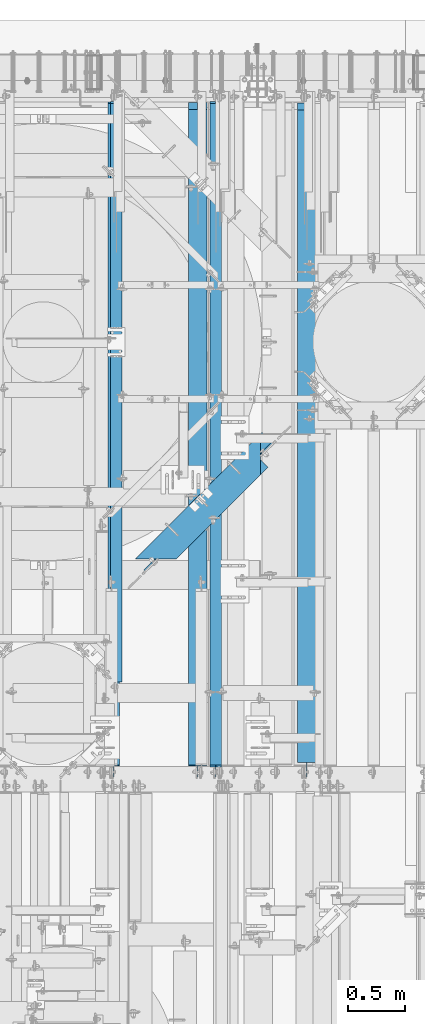
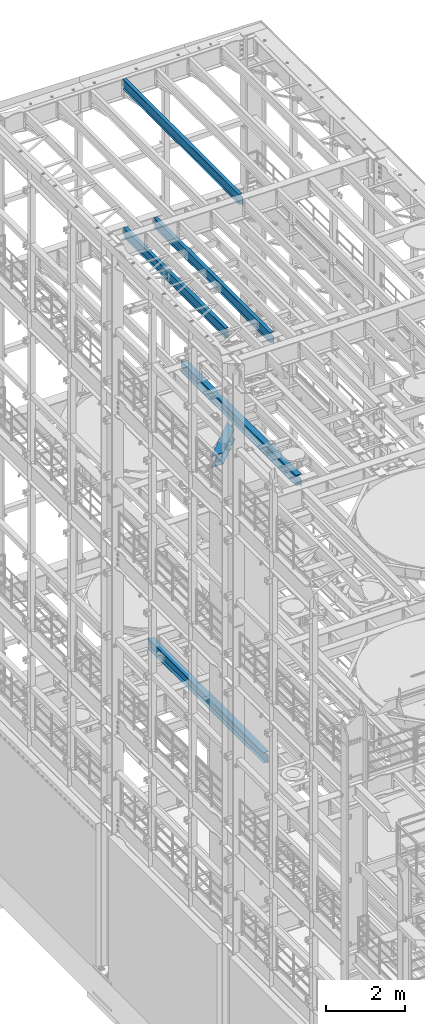
# One storey, part 1060 of 1876: 6 beams, 6 elements without a shape of their own.
"""IFC2X3 building model written with IfcOpenShell, lengths in millimetres."""

from ifc_helpers import new_model, si_unit, frame, origin_with_axes, place, context, subcontext, project, spatial, faceted_brep, material, type_object, element, aggregate, save


model = new_model("IFC2X3")

# Units and contexts
model_context = context("Model", 3, precision=1e-05, world=origin_with_axes())
body_context = subcontext(model_context, "Body", "Model", "MODEL_VIEW")
ifc_project = project(units=[si_unit("LENGTHUNIT", "METRE", prefix="MILLI"), si_unit("AREAUNIT", "SQUARE_METRE"), si_unit("VOLUMEUNIT", "CUBIC_METRE"), si_unit("MASSUNIT", "GRAM", prefix="KILO"), si_unit("TIMEUNIT", "SECOND"), si_unit("PLANEANGLEUNIT", "RADIAN"), si_unit("SOLIDANGLEUNIT", "STERADIAN"), si_unit("THERMODYNAMICTEMPERATUREUNIT", "DEGREE_CELSIUS"), si_unit("LUMINOUSINTENSITYUNIT", "LUMEN")], contexts=[model_context])

# Site, building, storey
site_placement = place(None, origin_with_axes())
site = spatial("IfcSite", under=ifc_project, at=site_placement, CompositionType="ELEMENT")
building_placement = place(site_placement, origin_with_axes())
building = spatial("IfcBuilding", under=site, at=building_placement, Name="Undefined", CompositionType="ELEMENT")
storey_placement = place(building_placement, origin_with_axes())
storey = spatial("IfcBuildingStorey", under=building, at=storey_placement, Name="Undefined", CompositionType="ELEMENT", Elevation=0.0)

# Assembly, beam
assembly_1_placement = place(storey_placement, origin_with_axes())
assembly_1 = element("IfcElementAssembly", 1, at=assembly_1_placement, inside=storey, Name="BEAM", AssemblyPlace="NOTDEFINED", PredefinedType="RIGID_FRAME")
ifc_material = material(Name="STEEL/A992")
beam_type_1 = type_object("IfcBeamType", Name="W12X16", PredefinedType="NOTDEFINED")
beam_1_placement = place(assembly_1_placement, frame((4711.7, 7620.0, 17830.8), z_axis=(0.0, 0.0, 1.0), x_axis=(0.0, 1.0, 0.0)))
beam_1 = element("IfcBeam", 2, at=beam_1_placement, type_object=beam_type_1, material=ifc_material, Name="BEAM", ObjectType="W12X16", context=body_context, shape_type="Brep", body=[
    faceted_brep([(19.84375, -3.17499999999995, -126.999999999996), (19.84375, 3.17499999999995, -126.999999999996), (96.0437501907345, 3.17500002364682, -126.999999999996), (96.0437501907345, -3.17499999999995, -126.999999999996), (100.90382970878, 3.17500002380461, -127.966729922584), (100.90382970878, -3.17499999999995, -127.966729922584), (105.024006176934, 3.17500002425209, -130.719743823061), (105.024006176934, -3.17499999999995, -130.719743823061), (107.777020077412, 3.17500002492102, -134.839920291215), (107.777020077412, -3.17499999999995, -134.839920291215), (108.74375, -3.17499999999995, -139.699999809261), (108.74375, 3.17500002570978, -139.699999809261), (108.74375, 3.17500009516311, -146.049999999999), (108.74375, 50.8, -146.049999999999), (108.74375, 50.8, -152.400000000001), (108.74375, -50.8, -152.400000000001), (108.74375, -50.8, -146.049999999999), (108.74375, -3.17499999999995, -146.049999999999), (5969.79375, 50.8, 146.049999999999), (5969.79375, 3.17499999999995, 146.049999999999), (126.20625, 3.17499999999995, 146.049999999999), (126.20625, 50.8, 146.049999999999), (113.506250190735, -3.17499999999995, 107.950000000004), (113.506250190735, 3.17499998606149, 107.950000000004), (19.84375, 3.17499999999995, 107.950000000004), (19.84375, -3.17499999999995, 107.950000000004), (118.366329708781, -3.17499999999995, 108.916729922592), (118.366329708781, 3.17499998590552, 108.916729922592), (122.486506176934, -3.17499999999995, 111.669743823069), (122.486506176934, 3.17499998546009, 111.669743823069), (125.239520077413, -3.17499999999995, 115.789920291223), (125.239520077413, 3.17499998479298, 115.789920291223), (126.20625, -3.17499999999995, 120.64999980927), (126.20625, 3.17499998400558, 120.64999980927), (5969.79375, -50.8, 152.400000000001), (5969.79375, 50.8, 152.400000000001), (126.20625, 50.8, 152.400000000001), (126.20625, -50.8, 152.400000000001), (5969.79375, -50.8, 146.049999999999), (126.20625, -50.8, 146.049999999999), (5969.79375, -3.17499999999995, 146.049999999999), (126.20625, -3.17499999999995, 146.049999999999), (5969.79375, -3.17499999999995, 120.64999980927), (5969.79375, 3.17499999999995, 120.64999980927), (5970.76047992259, -3.17499999999995, 115.789920291223), (5970.76047992259, 3.17499999999995, 115.789920291223), (5973.51349382307, -3.17499999999995, 111.669743823069), (5973.51349382307, 3.17499999999995, 111.669743823069), (5977.63367029122, -3.17499999999995, 108.916729922592), (5977.63367029122, 3.17499999999995, 108.916729922592), (5982.49374980927, -3.17499999999995, 107.950000000004), (5982.49374980927, 3.17499999999995, 107.950000000004), (6076.15625, -3.17499999999995, 107.950000000004), (6076.15625, 3.17499999999995, 107.950000000004), (6076.15625, -3.17499999999995, -126.999999999996), (6076.15625, 3.17499999999995, -126.999999999996), (5999.95624980926, -3.17499999999995, -126.999999999996), (5999.95624980926, 3.17499999999995, -126.999999999996), (5995.09617029122, -3.17499999999995, -127.966729922584), (5995.09617029122, 3.17499999999995, -127.966729922584), (5990.97599382306, -3.17499999999995, -130.719743823061), (5990.97599382306, 3.17499999999995, -130.719743823061), (5988.22297992259, -3.17499999999995, -134.839920291215), (5988.22297992259, 3.17499999999995, -134.839920291215), (5987.25625, -3.17499999999995, -139.699999809261), (5987.25625, 3.17499999999995, -139.699999809261), (5987.25625, -3.17499999999995, -146.049999999999), (5987.25625, -50.8, -146.049999999999), (5987.25625, -50.8, -152.400000000001), (5987.25625, 50.8, -152.400000000001), (5987.25625, 50.8, -146.049999999999), (5987.25625, 3.17499999999995, -146.049999999999)], [[[0, 1, 2, 3]], [[3, 2, 4, 5]], [[5, 4, 6, 7]], [[7, 6, 8, 9]], [[10, 11, 12, 13, 14, 15, 16, 17]], [[9, 8, 11, 10]], [[18, 19, 20, 21]], [[22, 23, 24, 25]], [[26, 27, 23, 22]], [[28, 29, 27, 26]], [[30, 31, 29, 28]], [[32, 33, 31, 30]], [[34, 35, 36, 37]], [[38, 34, 37, 39]], [[40, 38, 39, 41]], [[37, 36, 21, 20, 33, 32, 41, 39]], [[35, 18, 21, 36]], [[34, 38, 40, 42, 43, 19, 18, 35]], [[44, 45, 43, 42]], [[46, 47, 45, 44]], [[48, 49, 47, 46]], [[50, 51, 49, 48]], [[52, 53, 51, 50]], [[53, 52, 54, 55]], [[54, 56, 57, 55]], [[58, 59, 57, 56]], [[60, 61, 59, 58]], [[62, 63, 61, 60]], [[64, 65, 63, 62]], [[66, 67, 68, 69, 70, 71, 65, 64]], [[67, 66, 17, 16]], [[68, 67, 16, 15]], [[69, 68, 15, 14]], [[70, 69, 14, 13]], [[71, 70, 13, 12]], [[6, 4, 2, 1, 24, 23, 27, 29, 31, 33, 20, 19, 43, 45, 47, 49, 51, 53, 55, 57, 59, 61, 63, 65, 71, 12, 11, 8]], [[25, 24, 1, 0]], [[66, 64, 62, 60, 58, 56, 54, 52, 50, 48, 46, 44, 42, 40, 41, 32, 30, 28, 26, 22, 25, 0, 3, 5, 7, 9, 10, 17]]]),
])
aggregate(assembly_1, [beam_1])

assembly_2_placement = place(storey_placement, origin_with_axes())
assembly_2 = element("IfcElementAssembly", 3, at=assembly_2_placement, inside=storey, Name="BEAM", AssemblyPlace="NOTDEFINED", PredefinedType="RIGID_FRAME")
beam_2_placement = place(assembly_2_placement, frame((3832.225, 8382.0, 17830.8), z_axis=(0.0, 0.0, 1.0), x_axis=(0.0, 1.0, 0.0)))
beam_2 = element("IfcBeam", 4, at=beam_2_placement, type_object=beam_type_1, material=ifc_material, Name="BEAM", ObjectType="W12X16", context=body_context, shape_type="Brep", body=[
    faceted_brep([(15.8749999999982, -3.17500000000018, -127.0), (15.8749999999982, 3.17500000000018, -127.0), (95.2500001907392, 3.17500000000018, -127.0), (95.2500001907392, -3.17500000000018, -127.0), (100.110079708786, 3.17500000000018, -127.966729922588), (100.110079708786, -3.17500000000018, -127.966729922588), (104.230256176939, 3.17500000000018, -130.719743823065), (104.230256176939, -3.17500000000018, -130.719743823065), (106.983270077417, 3.17500000000018, -134.839920291219), (106.983270077417, -3.17500000000018, -134.839920291219), (107.950000000004, -3.17500000000018, -139.699999809265), (107.950000000004, 3.17500000000018, -139.699999809265), (107.950000000001, 3.17499999999927, -146.049999999999), (107.950000000004, 50.8000000000002, -146.049999999999), (107.950000000004, 50.8000000000002, -152.400000000001), (107.950000000004, -50.8000000000002, -152.400000000001), (107.950000000004, -50.8000000000002, -146.049999999999), (107.950000000001, -3.17499999999927, -146.049999999999), (5207.79375, 50.8000000000002, 146.049999999999), (5207.79375, 3.17500000000018, 146.049999999999), (95.2499999999982, 3.17500000000018, 146.049999999999), (95.2499999999982, 50.8000000000002, 146.049999999999), (82.5500001907385, -3.17500000000018, 133.349999999999), (82.5500001907385, 3.17500000000018, 133.349999999999), (15.875, 3.17500000000018, 133.349999999999), (15.875, -3.17500000000018, 133.349999999999), (87.4100797087849, -3.17500000000018, 134.316729922586), (87.4100797087849, 3.17500000000018, 134.316729922586), (91.5302561769386, -3.17500000000018, 137.069743823064), (91.5302561769386, 3.17500000000018, 137.069743823064), (94.2832700774161, -3.17500000000018, 141.189920291217), (94.2832700774161, 3.17500000000018, 141.189920291217), (95.2499999999982, -3.17500000000018, 146.049999999999), (5207.79375, -50.8000000000002, 152.400000000001), (5207.79375, 50.8000000000002, 152.400000000001), (95.2499999999982, 50.8000000000002, 152.400000000001), (95.2499999999982, -50.8000000000002, 152.400000000001), (5207.79375, -50.8000000000002, 146.049999999999), (95.2499999999982, -50.8000000000002, 146.049999999999), (5207.79375, -3.17500000000018, 146.049999999999), (5207.79375, -3.17500000000018, 120.64999980927), (5207.79375, 3.17500000000018, 120.64999980927), (5208.76047992259, -3.17500000000018, 115.789920291223), (5208.76047992259, 3.17500000000018, 115.789920291223), (5211.51349382307, -3.17500000000018, 111.669743823069), (5211.51349382307, 3.17500000000018, 111.669743823069), (5215.63367029122, -3.17500000000018, 108.916729922592), (5215.63367029122, 3.17500000000018, 108.916729922592), (5220.49374980927, -3.17500000000018, 107.950000000004), (5220.49374980927, 3.17500000000018, 107.950000000004), (5314.15625, -3.17500000000018, 107.950000000004), (5314.15625, 3.17500000000018, 107.950000000004), (5314.15625, -3.17500000000018, -126.999999999996), (5314.15625, 3.17500000000018, -126.999999999996), (5237.95624980926, -3.17500000000018, -126.999999999996), (5237.95624980926, 3.17500000000018, -126.999999999996), (5233.09617029122, -3.17500000000018, -127.966729922584), (5233.09617029122, 3.17500000000018, -127.966729922584), (5228.97599382306, -3.17500000000018, -130.719743823061), (5228.97599382306, 3.17500000000018, -130.719743823061), (5226.22297992259, -3.17500000000018, -134.839920291215), (5226.22297992259, 3.17500000000018, -134.839920291215), (5225.25625, -3.17500000000018, -139.699999809261), (5225.25625, 3.17500000000018, -139.699999809261), (5225.25625, -3.17500000000018, -146.049999999999), (5225.25625, -50.8000000000002, -146.049999999999), (5225.25625, -50.8000000000002, -152.400000000001), (5225.25625, 50.8000000000002, -152.400000000001), (5225.25625, 50.8000000000002, -146.049999999999), (5225.25625, 3.17500000000018, -146.049999999999)], [[[0, 1, 2, 3]], [[3, 2, 4, 5]], [[5, 4, 6, 7]], [[7, 6, 8, 9]], [[10, 11, 12, 13, 14, 15, 16, 17]], [[9, 8, 11, 10]], [[18, 19, 20, 21]], [[22, 23, 24, 25]], [[26, 27, 23, 22]], [[28, 29, 27, 26]], [[30, 31, 29, 28]], [[32, 20, 31, 30]], [[33, 34, 35, 36]], [[37, 33, 36, 38]], [[39, 37, 38, 32]], [[36, 35, 21, 20, 32, 38]], [[34, 18, 21, 35]], [[33, 37, 39, 40, 41, 19, 18, 34]], [[42, 43, 41, 40]], [[44, 45, 43, 42]], [[46, 47, 45, 44]], [[48, 49, 47, 46]], [[50, 51, 49, 48]], [[51, 50, 52, 53]], [[52, 54, 55, 53]], [[56, 57, 55, 54]], [[58, 59, 57, 56]], [[60, 61, 59, 58]], [[62, 63, 61, 60]], [[64, 65, 66, 67, 68, 69, 63, 62]], [[65, 64, 17, 16]], [[66, 65, 16, 15]], [[67, 66, 15, 14]], [[68, 67, 14, 13]], [[69, 68, 13, 12]], [[6, 4, 2, 1, 24, 23, 27, 29, 31, 20, 19, 41, 43, 45, 47, 49, 51, 53, 55, 57, 59, 61, 63, 69, 12, 11, 8]], [[25, 24, 1, 0]], [[64, 62, 60, 58, 56, 54, 52, 50, 48, 46, 44, 42, 40, 39, 32, 30, 28, 26, 22, 25, 0, 3, 5, 7, 9, 10, 17]]]),
])
aggregate(assembly_2, [beam_2])

assembly_3_placement = place(storey_placement, origin_with_axes())
assembly_3 = element("IfcElementAssembly", 5, at=assembly_3_placement, inside=storey, Name="BEAM", AssemblyPlace="NOTDEFINED", PredefinedType="RIGID_FRAME")
beam_3_placement = place(assembly_3_placement, frame((3810.0, 7620.0, 22402.8), z_axis=(0.0, 0.0, 1.0), x_axis=(0.0, 1.0, 0.0)))
beam_3 = element("IfcBeam", 6, at=beam_3_placement, type_object=beam_type_1, material=ifc_material, Name="BEAM", ObjectType="W12X16", context=body_context, shape_type="Brep", body=[
    faceted_brep([(19.84375, -3.17499999999995, -126.999999999996), (19.84375, 3.17499999999995, -126.999999999996), (102.393750190735, 3.17500000000018, -127.000000000001), (102.393750190735, -3.17500000000018, -127.000000000001), (107.25382970878, 3.17500000000018, -127.966729922588), (107.25382970878, -3.17500000000018, -127.966729922588), (111.374006176934, 3.17500000000018, -130.719743823067), (111.374006176934, -3.17500000000018, -130.719743823067), (114.127020077412, 3.17500000000018, -134.839920291221), (114.127020077412, -3.17500000000018, -134.839920291221), (115.09375, -3.17500000000018, -139.699999809266), (115.09375, 3.17500000000018, -139.699999809266), (115.09375, 3.17500000000018, -146.05), (115.09375, 50.8000000000002, -146.05), (115.09375, 50.8000000000002, -152.4), (115.09375, -50.8000000000002, -152.4), (115.09375, -50.8000000000002, -146.05), (115.09375, -3.17500000000018, -146.05), (127.79375, 3.17500000000018, 146.05), (127.79375, 50.8000000000002, 146.05), (5968.20625, 50.8, 146.05), (5968.20625, 3.17499999999995, 146.05), (115.093750190735, -3.17500000000018, 114.299999999999), (115.093750190735, 3.17500000000018, 114.299999999999), (19.84375, 3.17500000000018, 114.299999999999), (19.84375, -3.17500000000018, 114.299999999999), (119.95382970878, -3.17500000000018, 115.266729922587), (119.95382970878, 3.17500000000018, 115.266729922587), (124.074006176934, -3.17500000000018, 118.019743823065), (124.074006176934, 3.17500000000018, 118.019743823065), (126.827020077412, -3.17500000000018, 122.139920291219), (126.827020077412, 3.17500000000018, 122.139920291219), (127.79375, -3.17500000000018, 126.999999809264), (127.79375, 3.17500000000018, 126.999999809264), (127.79375, 50.8000000000002, 152.4), (127.79375, -50.8000000000002, 152.4), (5968.20625, -50.8, 152.4), (5968.20625, 50.8, 152.4), (127.79375, -50.8000000000002, 146.05), (5968.20625, -50.8, 146.05), (127.79375, -3.17500000000018, 146.05), (5968.20625, -3.17499999999995, 146.05), (5968.20625, -3.17499999999995, 126.999999809264), (5968.20625, 3.17499999999995, 126.999999809264), (5969.17297992259, -3.17499999999995, 122.139920291219), (5969.17297992259, 3.17499999999995, 122.139920291219), (5971.92599382307, -3.17499999999995, 118.019743823065), (5971.92599382307, 3.17499999999995, 118.019743823065), (5976.04617029122, -3.17499999999995, 115.266729922587), (5976.04617029122, 3.17499999999995, 115.266729922587), (5980.90624980927, -3.17499999999995, 114.299999999999), (5980.90624980927, 3.17499999999995, 114.299999999999), (6076.15625, -3.17499999999995, 114.299999999999), (6076.15625, 3.17499999999995, 114.299999999999), (6076.15625, -3.17499999999995, -126.999999999996), (6076.15625, 3.17499999999995, -126.999999999996), (5993.60624980927, -3.17499999999995, -127.000000000001), (5993.60624980927, 3.17499999999995, -127.000000000001), (5988.74617029122, -3.17499999999995, -127.966729922588), (5988.74617029122, 3.17499999999995, -127.966729922588), (5984.62599382307, -3.17499999999995, -130.719743823067), (5984.62599382307, 3.17499999999995, -130.719743823067), (5981.87297992259, -3.17499999999995, -134.839920291221), (5981.87297992259, 3.17499999999995, -134.839920291221), (5980.90625, -3.17499999999995, -139.699999809266), (5980.90625, 3.17499999999995, -139.699999809266), (5980.90625, -3.17499999999995, -146.05), (5980.90625, -50.8, -146.05), (5980.90625, -50.8, -152.4), (5980.90625, 50.8, -152.4), (5980.90625, 50.8, -146.05), (5980.90625, 3.17499999999995, -146.05)], [[[0, 1, 2, 3]], [[3, 2, 4, 5]], [[5, 4, 6, 7]], [[7, 6, 8, 9]], [[10, 11, 12, 13, 14, 15, 16, 17]], [[9, 8, 11, 10]], [[18, 19, 20, 21]], [[22, 23, 24, 25]], [[26, 27, 23, 22]], [[28, 29, 27, 26]], [[30, 31, 29, 28]], [[32, 33, 31, 30]], [[34, 35, 36, 37]], [[35, 38, 39, 36]], [[38, 40, 41, 39]], [[35, 34, 19, 18, 33, 32, 40, 38]], [[19, 34, 37, 20]], [[36, 39, 41, 42, 43, 21, 20, 37]], [[44, 45, 43, 42]], [[46, 47, 45, 44]], [[48, 49, 47, 46]], [[50, 51, 49, 48]], [[52, 53, 51, 50]], [[53, 52, 54, 55]], [[54, 56, 57, 55]], [[58, 59, 57, 56]], [[60, 61, 59, 58]], [[62, 63, 61, 60]], [[64, 65, 63, 62]], [[66, 67, 68, 69, 70, 71, 65, 64]], [[17, 16, 67, 66]], [[16, 15, 68, 67]], [[15, 14, 69, 68]], [[14, 13, 70, 69]], [[13, 12, 71, 70]], [[59, 61, 63, 65, 71, 12, 11, 8, 6, 4, 2, 1, 24, 23, 27, 29, 31, 33, 18, 21, 43, 45, 47, 49, 51, 53, 55, 57]], [[25, 24, 1, 0]], [[52, 50, 48, 46, 44, 42, 41, 40, 32, 30, 28, 26, 22, 25, 0, 3, 5, 7, 9, 10, 17, 66, 64, 62, 60, 58, 56, 54]]]),
])
aggregate(assembly_3, [beam_3])

assembly_4_placement = place(storey_placement, origin_with_axes())
assembly_4 = element("IfcElementAssembly", 7, at=assembly_4_placement, inside=storey, Name="BEAM", AssemblyPlace="NOTDEFINED", PredefinedType="RIGID_FRAME")
beam_type_2 = type_object("IfcBeamType", Name="W12X30", PredefinedType="NOTDEFINED")
beam_4_placement = place(assembly_4_placement, frame((5514.975, 7620.0, 13152.4375), z_axis=(0.0, 0.0, 1.0), x_axis=(0.0, 1.0, 0.0)))
beam_4 = element("IfcBeam", 8, at=beam_4_placement, type_object=beam_type_2, material=ifc_material, Name="BEAM", ObjectType="W12X30", context=body_context, shape_type="Brep", body=[
    faceted_brep([(5973.7625, -3.17500000000018, -146.049999999999), (5973.7625, -82.5500000000002, -146.049999999999), (5973.7625, -82.5500000000002, -157.1625), (5973.7625, 82.5500000000002, -157.1625), (5973.7625, 82.5500000000002, -146.049999999999), (5973.7625, 3.17500000000018, -146.049999999999), (5973.7625, 3.17500000000018, -144.462499809264), (5973.7625, -3.17500000000018, -144.462499809264), (5974.72922992259, 3.17500000000018, -139.602420291218), (5974.72922992259, -3.17500000000018, -139.602420291218), (5977.48224382307, 3.17500000000018, -135.482243823064), (5977.48224382307, -3.17500000000018, -135.482243823064), (5981.60242029122, 3.17500000000018, -132.729229922586), (5981.60242029122, -3.17500000000018, -132.729229922586), (5986.46249980926, 3.17500000000018, -131.762499999999), (5986.46249980926, -3.17500000000018, -131.762499999999), (6075.3625, -3.17500000000018, -131.762499999999), (6075.3625, 3.17500000000018, -131.762499999999), (146.84375, 3.17500000000018, 146.049999999999), (146.84375, 82.5500000000002, 146.049999999999), (5910.2625, 82.5500000000002, 146.049999999999), (5910.2625, 3.17500000000018, 146.049999999999), (146.84375, -3.17500000000018, -144.462499809266), (146.84375, 3.17500000000018, -144.462499809266), (146.84375, 3.17500000000018, -146.049999999999), (146.84375, 82.5500000000002, -146.049999999999), (146.84375, 82.5500000000002, -157.1625), (146.84375, -82.5500000000002, -157.1625), (146.84375, -82.5500000000002, -146.049999999999), (146.84375, -3.17500000000018, -146.049999999999), (145.877020077412, -3.17500000000018, -139.602420291219), (145.877020077412, 3.17500000000018, -139.602420291219), (143.124006176934, -3.17500000000018, -135.482243823066), (143.124006176934, 3.17500000000018, -135.482243823066), (139.00382970878, -3.17500000000018, -132.729229922588), (139.00382970878, 3.17500000000018, -132.729229922588), (134.143750190735, -3.17500000000018, -131.762500000001), (134.143750190735, 3.17500000000018, -131.762500000001), (19.8437500000002, -3.17500000000018, -131.762499999993), (19.8437500000002, 3.17500000000018, -131.762499999993), (19.8437491105051, -3.17499999999995, 119.062500000004), (19.8437491105051, 3.17499999999995, 119.062500000004), (134.143750190735, -3.17500000000018, 119.0625), (134.143750190735, 3.17500000000018, 119.0625), (139.00382970878, -3.17500000000018, 120.029229922588), (139.00382970878, 3.17500000000018, 120.029229922588), (143.124006176934, -3.17500000000018, 122.782243823065), (143.124006176934, 3.17500000000018, 122.782243823065), (145.877020077412, -3.17500000000018, 126.902420291219), (145.877020077412, 3.17500000000018, 126.902420291219), (146.84375, -3.17500000000018, 131.762499809265), (146.84375, 3.17500000000018, 131.762499809265), (146.84375, -82.5500000000002, 157.1625), (146.84375, 82.5500000000002, 157.1625), (146.84375, -3.17500000000018, 146.049999999999), (146.84375, -82.5500000000002, 146.049999999999), (5910.2625, -3.17500000000018, 146.049999999999), (5910.2625, -82.5500000000002, 146.049999999999), (5910.2625, -82.5500000000002, 157.1625), (5910.2625, 82.5500000000002, 157.1625), (5910.2625, -3.17500000000018, 125.412499809268), (5910.2625, 3.17500000000018, 125.412499809268), (5911.22922992259, -3.17500000000018, 120.552420291222), (5911.22922992259, 3.17500000000018, 120.552420291222), (5913.98224382307, -3.17500000000018, 116.432243823068), (5913.98224382307, 3.17500000000018, 116.432243823068), (5918.10242029122, -3.17500000000018, 113.679229922591), (5918.10242029122, 3.17500000000018, 113.679229922591), (5922.96249980926, -3.17500000000018, 112.712500000003), (5922.96249980926, 3.17500000000018, 112.712500000003), (6075.3625, -3.17500000000018, 112.712500000003), (6075.3625, 3.17500000000018, 112.712500000003)], [[[0, 1, 2, 3, 4, 5, 6, 7]], [[7, 6, 8, 9]], [[9, 8, 10, 11]], [[11, 10, 12, 13]], [[13, 12, 14, 15]], [[16, 15, 14, 17]], [[18, 19, 20, 21]], [[22, 23, 24, 25, 26, 27, 28, 29]], [[30, 31, 23, 22]], [[32, 33, 31, 30]], [[34, 35, 33, 32]], [[36, 37, 35, 34]], [[38, 39, 37, 36]], [[40, 41, 39, 38]], [[42, 43, 41, 40]], [[44, 45, 43, 42]], [[46, 47, 45, 44]], [[48, 49, 47, 46]], [[50, 51, 49, 48]], [[52, 53, 19, 18, 51, 50, 54, 55]], [[55, 54, 56, 57]], [[52, 55, 57, 58]], [[53, 52, 58, 59]], [[19, 53, 59, 20]], [[58, 57, 56, 60, 61, 21, 20, 59]], [[62, 63, 61, 60]], [[64, 65, 63, 62]], [[66, 67, 65, 64]], [[68, 69, 67, 66]], [[70, 71, 69, 68]], [[71, 70, 16, 17]], [[12, 10, 8, 6, 5, 24, 23, 31, 33, 35, 37, 39, 41, 43, 45, 47, 49, 51, 18, 21, 61, 63, 65, 67, 69, 71, 17, 14]], [[25, 24, 5, 4]], [[26, 25, 4, 3]], [[27, 26, 3, 2]], [[28, 27, 2, 1]], [[29, 28, 1, 0]], [[70, 68, 66, 64, 62, 60, 56, 54, 50, 48, 46, 44, 42, 40, 38, 36, 34, 32, 30, 22, 29, 0, 7, 9, 11, 13, 15, 16]]]),
])
aggregate(assembly_4, [beam_4])

assembly_5_placement = place(storey_placement, origin_with_axes())
assembly_5 = element("IfcElementAssembly", 9, at=assembly_5_placement, inside=storey, Name="BEAM", AssemblyPlace="NOTDEFINED", PredefinedType="RIGID_FRAME")
beam_5_placement = place(assembly_5_placement, frame((4552.95, 7620.0, 4973.6375), z_axis=(0.0, 0.0, 1.0), x_axis=(0.0, 1.0, 0.0)))
beam_5 = element("IfcBeam", 10, at=beam_5_placement, type_object=beam_type_2, material=ifc_material, Name="BEAM", ObjectType="W12X30", context=body_context, shape_type="Brep", body=[
    faceted_brep([(19.8437500000002, -3.17500000000018, -131.762499999993), (19.8437500000002, 3.17500000000018, -131.762499999993), (102.393750190735, 3.17500000000018, -131.762500000001), (102.393750190735, -3.17500000000018, -131.762500000001), (107.25382970878, 3.17500000000018, -132.729229922588), (107.25382970878, -3.17500000000018, -132.729229922588), (111.374006176934, 3.17500000000018, -135.482243823067), (111.374006176934, -3.17500000000018, -135.482243823067), (114.127020077412, 3.17500000000018, -139.60242029122), (114.127020077412, -3.17500000000018, -139.60242029122), (115.09375, -3.17500000000018, -144.462499809266), (115.09375, 3.17500000000018, -144.462499809266), (115.09375, 3.17500000000018, -146.05), (115.09375, 82.5500000000002, -146.05), (115.09375, 82.5500000000002, -157.1625), (115.09375, -82.5500000000002, -157.1625), (115.09375, -82.5500000000002, -146.05), (115.09375, -3.17500000000018, -146.05), (5914.23125, 82.5500000000002, 146.05), (5914.23125, 3.17500000000018, 146.05), (127.79375, 3.17500000000018, 146.05), (127.793782276814, 82.5500000000102, 146.05), (115.09374930124, -3.17499999999995, 119.062500000004), (115.09374930124, 3.17499999999995, 119.062500000004), (19.8437491105051, 3.17499999999995, 119.062500000004), (19.8437491105051, -3.17499999999995, 119.062500000004), (119.953828819285, -3.17499999999995, 120.029229922591), (119.953828819285, 3.17499999999995, 120.029229922591), (124.074005287439, -3.17499999999995, 122.782243823069), (124.074005287439, 3.17499999999995, 122.782243823069), (126.827019187917, -3.17499999999995, 126.902420291222), (126.827019187917, 3.17499999999995, 126.902420291222), (127.793749110505, -3.17499999999995, 131.762499809269), (127.793749110505, 3.17499999999995, 131.762499809269), (5914.23125, -82.5500000000002, 157.1625), (5914.23125, 82.5500000000002, 157.1625), (127.793749110505, 82.55, 157.162499999999), (127.793749110505, -82.55, 157.162499999999), (5914.23125, -82.5500000000002, 146.05), (127.793782276821, -82.5500000000029, 146.05), (5914.23125, -3.17500000000018, 146.05), (127.79375, -3.17500000000018, 146.05), (5914.23125, -3.17500000000018, 119.062499809265), (5914.23125, 3.17500000000018, 119.062499809265), (5915.19797992259, -3.17500000000018, 114.20242029122), (5915.19797992259, 3.17500000000018, 114.20242029122), (5917.95099382307, -3.17500000000018, 110.082243823066), (5917.95099382307, 3.17500000000018, 110.082243823066), (5922.07117029122, -3.17500000000018, 107.329229922588), (5922.07117029122, 3.17500000000018, 107.329229922588), (5926.93124980926, -3.17500000000018, 106.3625), (5926.93124980926, 3.17500000000018, 106.3625), (6072.98125, -3.17500000000018, 106.3625), (6072.98125, 3.17500000000018, 106.3625), (6072.98125, -3.17500000000018, -131.7625), (6072.98125, 3.17500000000018, -131.7625), (5990.43124980926, -3.17500000000018, -131.7625), (5990.43124980926, 3.17500000000018, -131.7625), (5985.57117029122, -3.17500000000018, -132.729229922587), (5985.57117029122, 3.17500000000018, -132.729229922587), (5981.45099382307, -3.17500000000018, -135.482243823066), (5981.45099382307, 3.17500000000018, -135.482243823066), (5978.69797992259, -3.17500000000018, -139.602420291219), (5978.69797992259, 3.17500000000018, -139.602420291219), (5977.73125, -3.17500000000018, -144.462499809265), (5977.73125, 3.17500000000018, -144.462499809265), (5977.73125, -3.17500000000018, -146.05), (5977.73125, -82.5500000000002, -146.05), (5977.73125, -82.5500000000002, -157.1625), (5977.73125, 82.5500000000002, -157.1625), (5977.73125, 82.5500000000002, -146.05), (5977.73125, 3.17500000000018, -146.05)], [[[0, 1, 2, 3]], [[3, 2, 4, 5]], [[5, 4, 6, 7]], [[7, 6, 8, 9]], [[10, 11, 12, 13, 14, 15, 16, 17]], [[9, 8, 11, 10]], [[18, 19, 20, 21]], [[22, 23, 24, 25]], [[26, 27, 23, 22]], [[28, 29, 27, 26]], [[30, 31, 29, 28]], [[32, 33, 31, 30]], [[34, 35, 36, 37]], [[38, 34, 37, 39]], [[40, 38, 39, 41]], [[37, 36, 21, 20, 33, 32, 41, 39]], [[35, 18, 21, 36]], [[34, 38, 40, 42, 43, 19, 18, 35]], [[44, 45, 43, 42]], [[46, 47, 45, 44]], [[48, 49, 47, 46]], [[50, 51, 49, 48]], [[52, 53, 51, 50]], [[53, 52, 54, 55]], [[54, 56, 57, 55]], [[58, 59, 57, 56]], [[60, 61, 59, 58]], [[62, 63, 61, 60]], [[64, 65, 63, 62]], [[66, 67, 68, 69, 70, 71, 65, 64]], [[67, 66, 17, 16]], [[68, 67, 16, 15]], [[69, 68, 15, 14]], [[70, 69, 14, 13]], [[71, 70, 13, 12]], [[6, 4, 2, 1, 24, 23, 27, 29, 31, 33, 20, 19, 43, 45, 47, 49, 51, 53, 55, 57, 59, 61, 63, 65, 71, 12, 11, 8]], [[25, 24, 1, 0]], [[66, 64, 62, 60, 58, 56, 54, 52, 50, 48, 46, 44, 42, 40, 41, 32, 30, 28, 26, 22, 25, 0, 3, 5, 7, 9, 10, 17]]]),
])
aggregate(assembly_5, [beam_5])

assembly_6_placement = place(storey_placement, origin_with_axes())
assembly_6 = element("IfcElementAssembly", 11, at=assembly_6_placement, inside=storey, Name="BEAM", AssemblyPlace="NOTDEFINED", PredefinedType="RIGID_FRAME")
beam_type_3 = type_object("IfcBeamType", Name="W14X68", PredefinedType="NOTDEFINED")
beam_6_placement = place(assembly_6_placement, frame((4127.45326681803, 9510.75923161773, 13131.8), z_axis=(0.0, 0.0, 1.0), x_axis=(0.707106781186548, 0.707106781186547, 0.0)))
beam_6 = element("IfcBeam", 12, at=beam_6_placement, type_object=beam_type_3, material=ifc_material, Name="BEAM", ObjectType="W14X68", context=body_context, shape_type="Brep", body=[
    faceted_brep([(201.021026906135, -127.000000000084, -158.75), (201.021026906135, -127.000000000084, -177.799999999999), (1351.99116468773, -127.000000000444, -177.799999999999), (1351.99116468773, -127.000000000444, -158.75), (79.5772767343296, -5.55625000002465, -158.75), (1351.99116468777, -5.55625000042528, -158.75), (1531.97046371265, 5.55624999952033, -158.75), (1531.9707518189, 126.999999999541, -158.75), (-52.9789734531969, 127.00000000004, -158.75), (68.4647767186088, 5.55624999998099, -158.75), (63.2042645517522, 5.5562499999819, -137.069743823065), (57.3774551069946, 5.55624999998463, -134.316729922588), (50.5042647334976, 5.55624999998599, -133.35), (-67.0669746869225, 5.55625000002192, -133.35), (-67.0669746869207, 5.55625000002374, 133.35), (50.5042647349837, 5.55624999998554, 133.35), (57.3774551084807, 5.55624999998417, 134.316729922588), (63.2042645532383, 5.5562499999819, 137.069743823065), (67.0976141514511, 5.55624999998008, 141.189920291219), (68.464776720095, 5.55624999998054, 146.049999809266), (68.464776720095, 5.55624999998054, 158.75), (1390.82684203923, 5.55624999956535, 158.75), (1390.82684203923, 5.55624999956581, 146.049999809266), (1392.19400460594, 5.55624999956444, 141.189920291219), (1396.08735419864, 5.55624999956353, 137.069743823065), (1401.91416363516, 5.55624999956217, 134.316729922588), (1408.78735399893, 5.5562499995599, 133.35), (1531.97046371265, 5.55624999952033, 133.35), (68.4647767186088, 5.55624999998099, -146.049999809266), (67.097614149965, 5.55624999997963, -141.189920291219), (78.210114165684, -5.55625000002556, -141.189920291219), (79.5772767343296, -5.55625000002465, -146.049999809266), (74.316764567473, -5.55625000002283, -137.069743823065), (68.4899551227154, -5.55625000002146, -134.316729922588), (61.6167647492184, -5.5562500000201, -133.35), (-67.0670724920128, -5.55624999997917, -133.35), (-67.0670724920128, -5.55624999997917, -132.50250038147), (-67.0670724920128, -5.55624999997872, 133.35), (61.6167647507045, -5.55625000001965, 133.35), (68.4899551242015, -5.55625000002146, 134.316729922588), (74.3167645689591, -5.55625000002328, 137.069743823065), (78.2101141671719, -5.5562500000251, 141.189920291219), (79.5772767358158, -5.5562500000251, 146.049999809266), (201.021026907621, -127.000000000084, 177.799999999999), (-52.9789734517108, 127.000000000039, 177.799999999999), (-52.9789734517108, 127.000000000039, 158.75), (79.5772767358158, -5.5562500000251, 158.75), (201.021026907621, -127.000000000084, 158.75), (1379.71434205495, -5.55625000043392, 158.75), (1258.27059222671, -127.000000000416, 158.75), (1258.27059222671, -127.000000000416, 177.799999999999), (1512.27059186746, 126.999999999547, 177.799999999999), (1512.27059186746, 126.999999999547, 158.75), (1379.71434205495, -5.55625000043392, 146.049999809266), (1381.08150462166, -5.55625000043301, 141.189920291219), (1384.97485421436, -5.55625000043574, 137.069743823065), (1390.80166365087, -5.55625000043756, 134.316729922588), (1397.67485401465, -5.55625000044029, 133.35), (1531.97043734998, -5.55625000048212, 133.35), (1531.9707518189, 126.999999999541, -177.799999999999), (1531.97043734998, -5.55625000048212, 130.915006484987), (1531.97043734998, -5.55625000048212, -137.0), (1531.97044022842, -5.55625000048394, -158.75), (1531.97043734998, -5.55625000047667, -177.799999999999), (-52.9789734531969, 127.00000000004, -177.799999999999), (1359.13491471564, -5.55625000042664, -158.75), (1359.13491471564, -5.55625010373024, -177.799999999999), (1351.99116468777, -5.55625009621008, -177.799999999999)], [[[0, 1, 2, 3]], [[4, 0, 3, 5]], [[6, 7, 8, 9]], [[10, 11, 12, 13, 14, 15, 16, 17, 18, 19, 20, 21, 22, 23, 24, 25, 26, 27, 6, 9, 28, 29]], [[30, 29, 28, 31]], [[32, 10, 29, 30]], [[33, 11, 10, 32]], [[34, 12, 11, 33]], [[35, 13, 12, 34]], [[36, 37, 14, 13, 35]], [[38, 15, 14, 37]], [[39, 16, 15, 38]], [[40, 17, 16, 39]], [[41, 18, 17, 40]], [[42, 19, 18, 41]], [[43, 44, 45, 20, 19, 42, 46, 47]], [[47, 46, 48, 49]], [[43, 47, 49, 50]], [[44, 43, 50, 51]], [[45, 44, 51, 52]], [[20, 45, 52, 21]], [[51, 50, 49, 48, 53, 22, 21, 52]], [[22, 53, 54, 23]], [[23, 54, 55, 24]], [[24, 55, 56, 25]], [[25, 56, 57, 26]], [[26, 57, 58, 27]], [[59, 7, 6, 27, 58, 60, 61, 62, 63]], [[7, 59, 64, 8]], [[0, 4, 31, 28, 9, 8, 64, 1]], [[5, 65, 62, 61, 60, 58, 57, 56, 55, 54, 53, 48, 46, 42, 41, 40, 39, 38, 37, 36, 35, 34, 33, 32, 30, 31, 4]], [[62, 65, 66, 63]], [[2, 1, 64, 59, 63, 66, 67]], [[65, 5, 67, 66]], [[3, 2, 67, 5]]]),
])
aggregate(assembly_6, [beam_6])

save(model, "model.ifc")
